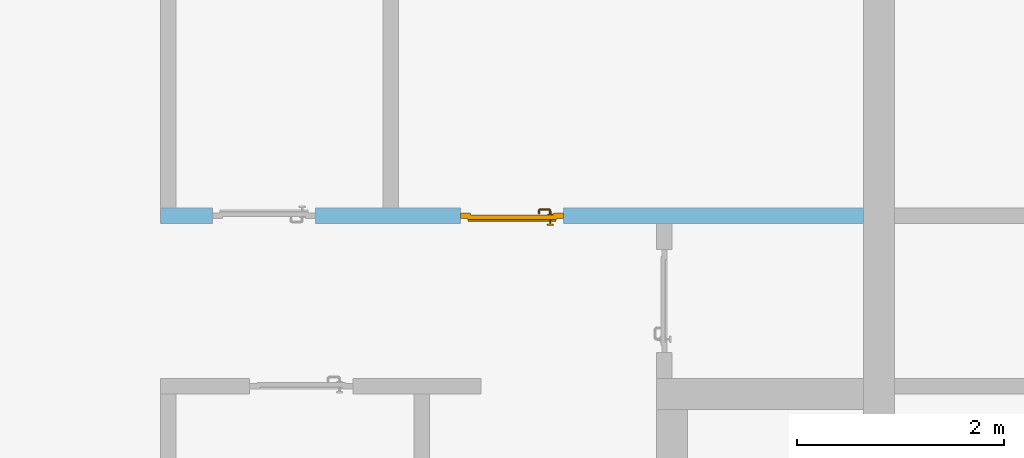
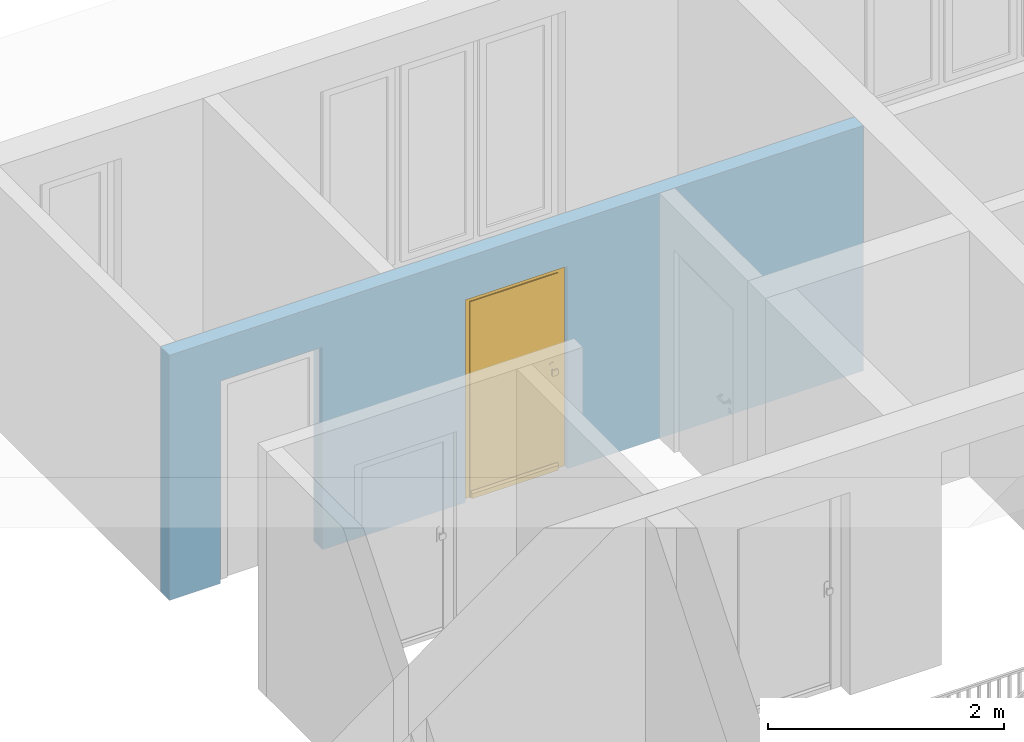
# One storey, part 25 of 54: 1 door, 2 openings, plus 1 element that does not belong to this part.
"""IFC4 building model written with IfcOpenShell, lengths in metres."""

from ifc_helpers import new_model, entity, si_unit, converted_unit, derived_unit, direction, frame, origin_with_axes, place, context, subcontext, project, spatial, polygons, source, transform, mapped, material, type_object, element, fill, save


model = new_model("IFC4")

# Units and contexts
model_context = context("Model", 3, precision=1e-05, world=origin_with_axes(), true_north=direction((0.0, 1.0)))
body_context = subcontext(model_context, "Body", "Model", "MODEL_VIEW")
ifc_project = project(units=[si_unit("LENGTHUNIT", "METRE"), si_unit("AREAUNIT", "SQUARE_METRE"), si_unit("VOLUMEUNIT", "CUBIC_METRE"), converted_unit("PLANEANGLEUNIT", "DEGREE", entity("IfcPlaneAngleMeasure", 0.0174532925199), si_unit("PLANEANGLEUNIT", "RADIAN"), dimensions=[0, 0, 0, 0, 0, 0, 0]), converted_unit("TIMEUNIT", "Year", entity("IfcTimeMeasure", 31556926.0), si_unit("TIMEUNIT", "SECOND"), dimensions=[0, 0, 1, 0, 0, 0, 0]), si_unit("MASSUNIT", "GRAM", prefix="KILO"), si_unit("THERMODYNAMICTEMPERATUREUNIT", "DEGREE_CELSIUS"), si_unit("LUMINOUSINTENSITYUNIT", "LUMEN"), si_unit("ENERGYUNIT", "JOULE", prefix="MEGA"), derived_unit("THERMALCONDUCTANCEUNIT", [(si_unit("POWERUNIT", "WATT"), 1), (si_unit("LENGTHUNIT", "METRE"), -1), (si_unit("THERMODYNAMICTEMPERATUREUNIT", "KELVIN"), -1)]), derived_unit("SPECIFICHEATCAPACITYUNIT", [(si_unit("ENERGYUNIT", "JOULE"), 1), (si_unit("MASSUNIT", "GRAM", prefix="KILO"), -1), (si_unit("THERMODYNAMICTEMPERATUREUNIT", "KELVIN"), -1)]), derived_unit("MASSDENSITYUNIT", [(si_unit("MASSUNIT", "GRAM", prefix="KILO"), 1), (si_unit("VOLUMEUNIT", "CUBIC_METRE"), -1)])], contexts=[model_context])

# Site, building, storey
site_placement = place(None, origin_with_axes())
site = spatial("IfcSite", under=ifc_project, at=site_placement, CompositionType="ELEMENT")
building_placement = place(site_placement, origin_with_axes())
building = spatial("IfcBuilding", under=site, at=building_placement, CompositionType="ELEMENT")
storey_placement = place(building_placement, frame((0.0, 0.0, 6.29), z_axis=(0.0, 0.0, 1.0), x_axis=(1.0, 0.0, 0.0)))
storey = spatial("IfcBuildingStorey", under=building, at=storey_placement, Name="2. Geschoss", CompositionType="ELEMENT", Elevation=6.29)

# Wall, openings, door
ifc_material = material()
wall_type = type_object("IfcWallType", Name="150", PredefinedType="NOTDEFINED")
wall_placement = place(storey_placement, frame((-7.5421993804, 5.47118776896, 0.0), z_axis=(0.0, 0.0, 1.0), x_axis=(1.0, 0.0, 0.0)))
wall = element("IfcWall", 1, at=wall_placement, inside=storey, type_object=wall_type, material=ifc_material, Name="Wand-002", PredefinedType="NOTDEFINED", context=body_context, shape_type="Tessellation", body=[
    polygons([(2.9, 0.15, 2.1), (2.9, 0.15, 0.0), (1.5, 0.15, 0.0), (1.5, 0.15, 2.1), (0.5, 0.15, 2.1), (0.5, 0.15, 0.0), (0.0, 0.15, 0.0), (0.0, 0.15, 2.54), (6.8, 0.15, 2.54), (6.8, 0.15, 0.0), (3.9, 0.15, 0.0), (3.9, 0.15, 2.1), (2.9, 0.05, 2.1), (2.9, 0.05, 0.0), (2.9, 0.0, 0.0), (1.5, 0.0, 0.0), (1.5, 0.1, 0.0), (1.5, 0.1, 2.1), (0.5, 0.1, 2.1), (0.5, 0.1, 0.0), (0.5, 0.0, 0.0), (0.0, 0.0, 0.0), (0.0, 0.0, 2.54), (6.8, 0.0, 2.54), (6.8, 0.0, 0.0), (3.9, 0.05, 0.0), (3.9, 0.0, 0.0), (3.9, 0.05, 2.1), (2.9, 0.0, 2.1), (3.9, 0.0, 2.1), (0.5, 0.0, 2.1), (1.5, 0.0, 2.1)], [[[1, 2, 3, 4, 5, 6, 7, 8, 9, 10, 11, 12]], [[2, 1, 13, 14]], [[2, 14, 15, 16, 17, 3]], [[4, 3, 17, 18]], [[5, 4, 18, 19]], [[6, 5, 19, 20]], [[6, 20, 21, 22, 7]], [[22, 23, 8, 7]], [[23, 24, 9, 8]], [[10, 9, 24, 25]], [[26, 11, 10, 25, 27]], [[12, 11, 26, 28]], [[1, 12, 28, 13]], [[14, 13, 29, 15]], [[16, 15, 29, 30, 27, 25, 24, 23, 22, 21, 31, 32]], [[16, 32, 18, 17]], [[32, 31, 19, 18]], [[31, 21, 20, 19]], [[28, 26, 27, 30]], [[13, 28, 30, 29]]], closed=True),
])
opening_1_placement = place(wall_placement, frame((1.0, 0.0, 0.0), z_axis=(0.0, 0.0, 1.0), x_axis=(1.0, 0.0, 0.0)))
element("IfcOpeningElement", 2, at=opening_1_placement, cuts=wall, context=body_context, identifier="Reference", shape_type="Tessellation", body=[
    polygons([(-0.5, 0.1, 0.0), (-0.5, 0.1, 2.1), (-0.5, 0.151, 2.1), (-0.5, 0.151, 0.0), (-0.5, -0.001, 0.0), (-0.5, -0.001, 2.1), (0.5, 0.1, 2.1), (0.5, 0.151, 2.1), (0.5, -0.001, 2.1), (0.5, 0.151, 0.0), (0.5, 0.1, 0.0), (0.5, -0.001, 0.0)], [[[1, 2, 3, 4]], [[2, 1, 5, 6]], [[7, 8, 3, 2, 6, 9]], [[8, 10, 4, 3]], [[1, 4, 10, 11, 12, 5]], [[6, 5, 12, 9]], [[7, 11, 10, 8]], [[11, 7, 9, 12]]], closed=True),
])
opening_2_placement = place(wall_placement, frame((3.4, 0.0, 0.0), z_axis=(0.0, 0.0, 1.0), x_axis=(1.0, 0.0, 0.0)))
opening_2 = element("IfcOpeningElement", 3, at=opening_2_placement, cuts=wall, context=body_context, identifier="Reference", shape_type="Tessellation", body=[
    polygons([(0.5, 0.05, 0.0), (0.5, 0.05, 2.1), (0.5, -0.001, 2.1), (0.5, -0.001, 0.0), (0.5, 0.151, 0.0), (0.5, 0.151, 2.1), (-0.5, 0.05, 2.1), (-0.5, -0.001, 2.1), (-0.5, 0.151, 2.1), (-0.5, -0.001, 0.0), (-0.5, 0.05, 0.0), (-0.5, 0.151, 0.0)], [[[1, 2, 3, 4]], [[2, 1, 5, 6]], [[7, 8, 3, 2, 6, 9]], [[8, 10, 4, 3]], [[1, 4, 10, 11, 12, 5]], [[6, 5, 12, 9]], [[7, 11, 10, 8]], [[11, 7, 9, 12]]], closed=True),
])
door_type = type_object("IfcDoorType", Name="Eingang 01 1-Fl 26", OperationType="SINGLE_SWING_RIGHT", PredefinedType="DOOR")
shared_shape = source(origin_with_axes(), body_context, "Body", "Tessellation", [
    polygons([(0.5, -0.05, 0.0), (0.5, -0.03, 0.0), (0.5, -0.03, 2.1), (0.5, -0.05, 2.1), (0.4, -0.05, 0.0), (0.4, -0.03, 0.0), (0.4, -0.03, 2.0), (0.1301, -0.03, 2.0), (0.0001, -0.03, 2.0), (-0.4, -0.03, 2.0), (-0.4, -0.03, 0.0), (-0.5, -0.03, 0.0), (-0.5, -0.03, 2.1), (-0.5, -0.05, 2.1), (-0.5, -0.05, 0.0), (-0.4, -0.05, 0.0), (-0.4, -0.05, 2.0), (0.0001, -0.05, 2.0), (0.1301, -0.05, 2.0), (0.4, -0.05, 2.0)], [[[1, 2, 3, 4]], [[5, 6, 2, 1]], [[2, 6, 7, 8, 9, 10, 11, 12, 13, 3]], [[4, 3, 13, 14]], [[1, 4, 14, 15, 16, 17, 18, 19, 20, 5]], [[20, 7, 6, 5]], [[19, 8, 7, 20]], [[18, 9, 8, 19]], [[17, 10, 9, 18]], [[16, 11, 10, 17]], [[15, 12, 11, 16]], [[14, 13, 12, 15]]], closed=True),
    polygons([(0.5, -0.03, 0.0), (0.5, 0.0, 0.0), (0.5, 0.0, 2.1), (0.5, -0.03, 2.1), (0.43, -0.03, 0.0), (0.43, 0.0, 0.0), (0.43, 0.0, 2.03), (0.1001, 0.0, 2.03), (0.0301, 0.0, 2.03), (-0.43, 0.0, 2.03), (-0.43, 0.0, 0.0), (-0.5, 0.0, 0.0), (-0.5, 0.0, 2.1), (-0.5, -0.03, 2.1), (-0.5, -0.03, 0.0), (-0.43, -0.03, 0.0), (-0.43, -0.03, 2.03), (0.0301, -0.03, 2.03), (0.1001, -0.03, 2.03), (0.43, -0.03, 2.03)], [[[1, 2, 3, 4]], [[5, 6, 2, 1]], [[2, 6, 7, 8, 9, 10, 11, 12, 13, 3]], [[4, 3, 13, 14]], [[1, 4, 14, 15, 16, 17, 18, 19, 20, 5]], [[20, 7, 6, 5]], [[19, 8, 7, 20]], [[18, 9, 8, 19]], [[17, 10, 9, 18]], [[16, 11, 10, 17]], [[15, 12, 11, 16]], [[14, 13, 12, 15]]], closed=True),
    polygons([(0.43, 0.01, 0.0), (-0.43, 0.01, 0.0), (-0.43, 0.01, 2.03), (0.43, 0.01, 2.03), (0.43, -0.03, 0.0), (-0.43, -0.03, 0.0), (-0.43, -0.03, 2.03), (0.43, -0.03, 2.03)], [[[1, 2, 3, 4]], [[2, 1, 5, 6]], [[3, 2, 6, 7]], [[4, 3, 7, 8]], [[1, 4, 8, 5]], [[6, 5, 8, 7]]], closed=True),
    polygons([(0.425, 0.03, 0.0), (-0.425, 0.03, 0.0), (-0.425, 0.03, 0.05), (0.425, 0.03, 0.05), (0.425, 0.01, 0.0), (-0.425, 0.01, 0.0), (-0.425, 0.01, 0.07), (-0.425, 0.015, 0.07), (0.425, 0.015, 0.07), (0.425, 0.01, 0.07)], [[[1, 2, 3, 4]], [[5, 6, 2, 1]], [[2, 6, 7, 8, 3]], [[4, 3, 8, 9]], [[1, 4, 9, 10, 5]], [[10, 7, 6, 5]], [[9, 8, 7, 10]]], closed=True),
    polygons([(-0.3835, -0.04, 1.0733826859), (-0.37, -0.04, 1.077), (-0.37, -0.0399, 1.077), (-0.3835, -0.0399, 1.0733826859), (-0.393382685902, -0.04, 1.0635), (-0.397, -0.04, 1.05), (-0.393382685902, -0.04, 1.0365), (-0.3835, -0.04, 1.0266173141), (-0.37, -0.04, 1.023), (-0.3565, -0.04, 1.0266173141), (-0.346617314098, -0.04, 1.0365), (-0.343, -0.04, 1.05), (-0.346617314098, -0.04, 1.0635), (-0.3565, -0.04, 1.0733826859), (-0.3565, -0.0399, 1.0733826859), (-0.37, -0.0301, 1.077), (-0.3835, -0.0301, 1.0733826859), (-0.393382685902, -0.0399, 1.0635), (-0.397, -0.0399, 1.05), (-0.393382685902, -0.0399, 1.0365), (-0.3835, -0.0399, 1.0266173141), (-0.37, -0.0399, 1.023), (-0.3565, -0.0399, 1.0266173141), (-0.346617314098, -0.0399, 1.0365), (-0.343, -0.0399, 1.05), (-0.346617314098, -0.0399, 1.0635), (-0.3565, -0.0301, 1.0733826859), (-0.37, -0.03, 1.077), (-0.3835, -0.03, 1.0733826859), (-0.393382685902, -0.0301, 1.0635), (-0.397, -0.0301, 1.05), (-0.393382685902, -0.0301, 1.0365), (-0.3835, -0.0301, 1.0266173141), (-0.37, -0.0301, 1.023), (-0.3565, -0.0301, 1.0266173141), (-0.346617314098, -0.0301, 1.0365), (-0.343, -0.0301, 1.05), (-0.346617314098, -0.0301, 1.0635), (-0.3565, -0.03, 1.0733826859), (-0.346617314098, -0.03, 1.0635), (-0.343, -0.03, 1.05), (-0.346617314098, -0.03, 1.0365), (-0.3565, -0.03, 1.0266173141), (-0.37, -0.03, 1.023), (-0.3835, -0.03, 1.0266173141), (-0.393382685902, -0.03, 1.0365), (-0.397, -0.03, 1.05), (-0.393382685902, -0.03, 1.0635)], [[[1, 2, 3, 4]], [[2, 1, 5, 6, 7, 8, 9, 10, 11, 12, 13, 14]], [[2, 14, 15, 3]], [[4, 3, 16, 17]], [[5, 1, 4, 18]], [[6, 5, 18, 19]], [[7, 6, 19, 20]], [[8, 7, 20, 21]], [[9, 8, 21, 22]], [[10, 9, 22, 23]], [[11, 10, 23, 24]], [[12, 11, 24, 25]], [[13, 12, 25, 26]], [[14, 13, 26, 15]], [[3, 15, 27, 16]], [[17, 16, 28, 29]], [[18, 4, 17, 30]], [[19, 18, 30, 31]], [[20, 19, 31, 32]], [[21, 20, 32, 33]], [[22, 21, 33, 34]], [[23, 22, 34, 35]], [[24, 23, 35, 36]], [[25, 24, 36, 37]], [[26, 25, 37, 38]], [[15, 26, 38, 27]], [[16, 27, 39, 28]], [[28, 39, 40, 41, 42, 43, 44, 45, 46, 47, 48, 29]], [[30, 17, 29, 48]], [[31, 30, 48, 47]], [[32, 31, 47, 46]], [[33, 32, 46, 45]], [[34, 33, 45, 44]], [[35, 34, 44, 43]], [[36, 35, 43, 42]], [[37, 36, 42, 41]], [[38, 37, 41, 40]], [[27, 38, 40, 39]]], closed=True),
    polygons([(-0.362532169224, -0.04, 0.959692280177), (-0.365, -0.04, 0.9544), (-0.365, -0.04, 0.952886751346), (-0.346703916638, -0.04, 0.96345), (-0.35655, -0.04, 0.973296083362), (-0.363279754556, -0.04, 0.961639806549), (-0.362532169224, -0.039, 0.959692280177), (-0.365, -0.039, 0.9544), (-0.365, -0.039, 0.952886751346), (-0.365, -0.039, 0.95), (-0.365, -0.039, 0.947113248654), (-0.365, -0.039, 0.941339745962), (-0.365, -0.039, 0.9375), (-0.365, -0.04, 0.9375), (-0.365, -0.04, 0.941339745962), (-0.365, -0.04, 0.947113248654), (-0.365, -0.04, 0.95), (-0.3431, -0.04, 0.95), (-0.346617314098, -0.04, 0.9635), (-0.3565, -0.04, 0.973382685902), (-0.364624817685, -0.04, 0.965143815798), (-0.37, -0.04, 0.9769), (-0.37, -0.04, 0.967425445323), (-0.364624817685, -0.039, 0.965143815798), (-0.363279754556, -0.039, 0.961639806549), (-0.35705, -0.039, 0.972430057958), (-0.347569942042, -0.039, 0.96295), (-0.3441, -0.039, 0.95), (-0.347569942042, -0.039, 0.93705), (-0.35705, -0.039, 0.927569942042), (-0.37, -0.039, 0.9241), (-0.37, -0.039, 0.9325), (-0.366464466094, -0.039, 0.933964466094), (-0.366464466094, -0.04, 0.933964466094), (-0.35655, -0.04, 0.926703916638), (-0.37, -0.04, 0.9325), (-0.37, -0.04, 0.9231), (-0.346703916638, -0.04, 0.93655), (-0.343, -0.04, 0.95), (-0.346617314098, -0.0399, 0.9635), (-0.3565, -0.0399, 0.973382685902), (-0.37, -0.04, 0.977), (-0.375375182315, -0.04, 0.965143815798), (-0.38345, -0.04, 0.973296083362), (-0.376720245444, -0.04, 0.961639806549), (-0.37, -0.039, 0.967425445323), (-0.37, -0.039, 0.9759), (-0.357, -0.039, 0.972516660498), (-0.347483339502, -0.039, 0.963), (-0.344, -0.039, 0.95), (-0.347483339502, -0.039, 0.937), (-0.357, -0.039, 0.927483339502), (-0.38295, -0.039, 0.927569942042), (-0.375, -0.039, 0.941339745962), (-0.375, -0.039, 0.9375), (-0.373535533906, -0.039, 0.933964466094), (-0.37, -0.039, 0.924), (-0.373535533906, -0.04, 0.933964466094), (-0.375, -0.04, 0.9375), (-0.375, -0.04, 0.941339745962), (-0.38345, -0.04, 0.926703916638), (-0.37, -0.04, 0.923), (-0.3565, -0.04, 0.926617314098), (-0.346617314098, -0.04, 0.9365), (-0.343, -0.0399, 0.95), (-0.346617314098, -0.0301, 0.9635), (-0.3565, -0.0301, 0.973382685902), (-0.37, -0.0399, 0.977), (-0.3835, -0.04, 0.973382685902), (-0.375375182315, -0.039, 0.965143815798), (-0.377467830776, -0.04, 0.959692280177), (-0.393296083362, -0.04, 0.96345), (-0.375, -0.04, 0.952886751346), (-0.375, -0.04, 0.9544), (-0.377467830776, -0.039, 0.959692280177), (-0.376720245444, -0.039, 0.961639806549), (-0.38295, -0.039, 0.972430057958), (-0.37, -0.039, 0.976), (-0.357, -0.0389, 0.972516660498), (-0.347483339502, -0.0389, 0.963), (-0.344, -0.0389, 0.95), (-0.347483339502, -0.0389, 0.937), (-0.357, -0.0389, 0.927483339502), (-0.392430057958, -0.039, 0.93705), (-0.375, -0.039, 0.947113248654), (-0.375, -0.039, 0.9544), (-0.375, -0.04, 0.95), (-0.375, -0.04, 0.947113248654), (-0.375, -0.039, 0.95), (-0.375, -0.039, 0.952886751346), (-0.383, -0.039, 0.927483339502), (-0.37, -0.0389, 0.924), (-0.393296083362, -0.04, 0.93655), (-0.3835, -0.04, 0.926617314098), (-0.37, -0.0399, 0.923), (-0.3565, -0.0399, 0.926617314098), (-0.346617314098, -0.0399, 0.9365), (-0.343, -0.0301, 0.95), (-0.346617314098, -0.03, 0.9635), (-0.3565, -0.03, 0.973382685902), (-0.37, -0.0301, 0.977), (-0.3835, -0.0399, 0.973382685902), (-0.393382685902, -0.04, 0.9635), (-0.3969, -0.04, 0.95), (-0.392430057958, -0.039, 0.96295), (-0.383, -0.039, 0.972516660498), (-0.37, -0.0389, 0.976), (-0.357, -0.0301, 0.972516660498), (-0.347483339502, -0.0301, 0.963), (-0.344, -0.0301, 0.95), (-0.347483339502, -0.0301, 0.937), (-0.357, -0.0301, 0.927483339502), (-0.392516660498, -0.039, 0.937), (-0.3959, -0.039, 0.95), (-0.383, -0.0389, 0.927483339502), (-0.37, -0.0301, 0.924), (-0.393382685902, -0.04, 0.9365), (-0.3835, -0.0399, 0.926617314098), (-0.37, -0.0301, 0.923), (-0.3565, -0.0301, 0.926617314098), (-0.346617314098, -0.0301, 0.9365), (-0.343, -0.03, 0.95), (-0.346703916638, -0.03, 0.96345), (-0.35655, -0.03, 0.973296083362), (-0.37, -0.03, 0.977), (-0.3835, -0.0301, 0.973382685902), (-0.393382685902, -0.0399, 0.9635), (-0.397, -0.04, 0.95), (-0.392516660498, -0.039, 0.963), (-0.383, -0.0389, 0.972516660498), (-0.37, -0.0301, 0.976), (-0.357, -0.03, 0.972516660498), (-0.347483339502, -0.03, 0.963), (-0.344, -0.03, 0.95), (-0.347483339502, -0.03, 0.937), (-0.357, -0.03, 0.927483339502), (-0.392516660498, -0.0389, 0.937), (-0.396, -0.039, 0.95), (-0.383, -0.0301, 0.927483339502), (-0.37, -0.03, 0.924), (-0.393382685902, -0.0399, 0.9365), (-0.3835, -0.0301, 0.926617314098), (-0.37, -0.03, 0.923), (-0.3565, -0.03, 0.926617314098), (-0.346617314098, -0.03, 0.9365), (-0.3431, -0.03, 0.95), (-0.347396736961, -0.03, 0.96305), (-0.35695, -0.03, 0.972603263039), (-0.37, -0.03, 0.9769), (-0.3835, -0.03, 0.973382685902), (-0.393382685902, -0.0301, 0.9635), (-0.397, -0.0399, 0.95), (-0.392516660498, -0.0389, 0.963), (-0.383, -0.0301, 0.972516660498), (-0.37, -0.03, 0.976), (-0.3439, -0.03, 0.95), (-0.347396736961, -0.03, 0.93695), (-0.35695, -0.03, 0.927396736961), (-0.392516660498, -0.0301, 0.937), (-0.396, -0.0389, 0.95), (-0.383, -0.03, 0.927483339502), (-0.37, -0.03, 0.9239), (-0.393382685902, -0.0301, 0.9365), (-0.3835, -0.03, 0.926617314098), (-0.37, -0.03, 0.9231), (-0.35655, -0.03, 0.926703916638), (-0.346703916638, -0.03, 0.93655), (-0.37, -0.03, 0.9761), (-0.38345, -0.03, 0.973296083362), (-0.393382685902, -0.03, 0.9635), (-0.397, -0.0301, 0.95), (-0.392516660498, -0.0301, 0.963), (-0.383, -0.03, 0.972516660498), (-0.392516660498, -0.03, 0.937), (-0.396, -0.0301, 0.95), (-0.38305, -0.03, 0.927396736961), (-0.393382685902, -0.03, 0.9365), (-0.38345, -0.03, 0.926703916638), (-0.38305, -0.03, 0.972603263039), (-0.393296083362, -0.03, 0.96345), (-0.397, -0.03, 0.95), (-0.392516660498, -0.03, 0.963), (-0.392603263039, -0.03, 0.93695), (-0.396, -0.03, 0.95), (-0.393296083362, -0.03, 0.93655), (-0.392603263039, -0.03, 0.96305), (-0.3969, -0.03, 0.95), (-0.3961, -0.03, 0.95)], [[[1, 2, 3, 4, 5, 6]], [[2, 1, 7, 8]], [[2, 8, 9, 10, 11, 12, 13, 14, 15, 16, 17, 3]], [[17, 18, 4, 3]], [[19, 20, 5, 4]], [[21, 6, 5, 22, 23]], [[1, 6, 21, 24, 25, 7]], [[7, 25, 26, 27, 9, 8]], [[9, 27, 28, 10]], [[10, 28, 29, 11]], [[11, 29, 30, 12]], [[31, 32, 33, 13, 12, 30]], [[14, 13, 33, 34]], [[35, 15, 14, 34, 36, 37]], [[15, 35, 38, 16]], [[16, 38, 18, 17]], [[39, 19, 4, 18]], [[40, 41, 20, 19]], [[20, 42, 22, 5]], [[43, 23, 22, 44, 45]], [[21, 23, 46, 24]], [[24, 46, 47, 26, 25]], [[27, 26, 48, 49]], [[28, 27, 49, 50]], [[29, 28, 50, 51]], [[30, 29, 51, 52]], [[53, 54, 55, 56, 32, 31]], [[34, 33, 32, 36]], [[31, 30, 52, 57]], [[37, 36, 58, 59, 60, 61]], [[62, 63, 35, 37]], [[63, 64, 38, 35]], [[64, 39, 18, 38]], [[65, 40, 19, 39]], [[66, 67, 41, 40]], [[41, 68, 42, 20]], [[42, 69, 44, 22]], [[23, 43, 70, 46]], [[71, 45, 44, 72, 73, 74]], [[43, 45, 71, 75, 76, 70]], [[70, 76, 77, 47, 46]], [[26, 47, 78, 48]], [[49, 48, 79, 80]], [[50, 49, 80, 81]], [[51, 50, 81, 82]], [[52, 51, 82, 83]], [[54, 53, 84, 85]], [[86, 74, 73, 87, 88, 60, 59, 55, 54, 85, 89, 90]], [[58, 56, 55, 59]], [[36, 32, 56, 58]], [[53, 31, 57, 91]], [[57, 52, 83, 92]], [[88, 93, 61, 60]], [[94, 62, 37, 61]], [[95, 96, 63, 62]], [[96, 97, 64, 63]], [[97, 65, 39, 64]], [[98, 66, 40, 65]], [[99, 100, 67, 66]], [[67, 101, 68, 41]], [[68, 102, 69, 42]], [[69, 103, 72, 44]], [[73, 72, 104, 87]], [[71, 74, 86, 75]], [[75, 86, 90, 105, 77, 76]], [[47, 77, 106, 78]], [[48, 78, 107, 79]], [[80, 79, 108, 109]], [[81, 80, 109, 110]], [[82, 81, 110, 111]], [[83, 82, 111, 112]], [[84, 53, 91, 113]], [[85, 84, 114, 89]], [[87, 104, 93, 88]], [[89, 114, 105, 90]], [[91, 57, 92, 115]], [[92, 83, 112, 116]], [[117, 94, 61, 93]], [[118, 95, 62, 94]], [[119, 120, 96, 95]], [[120, 121, 97, 96]], [[121, 98, 65, 97]], [[122, 99, 66, 98]], [[123, 124, 100, 99]], [[100, 125, 101, 67]], [[101, 126, 102, 68]], [[102, 127, 103, 69]], [[103, 128, 104, 72]], [[77, 105, 129, 106]], [[78, 106, 130, 107]], [[79, 107, 131, 108]], [[109, 108, 132, 133]], [[110, 109, 133, 134]], [[111, 110, 134, 135]], [[112, 111, 135, 136]], [[113, 91, 115, 137]], [[114, 84, 113, 138]], [[128, 117, 93, 104]], [[105, 114, 138, 129]], [[115, 92, 116, 139]], [[116, 112, 136, 140]], [[141, 118, 94, 117]], [[142, 119, 95, 118]], [[143, 144, 120, 119]], [[144, 145, 121, 120]], [[145, 122, 98, 121]], [[146, 123, 99, 122]], [[147, 148, 124, 123]], [[124, 149, 125, 100]], [[125, 150, 126, 101]], [[126, 151, 127, 102]], [[127, 152, 128, 103]], [[106, 129, 153, 130]], [[107, 130, 154, 131]], [[108, 131, 155, 132]], [[133, 132, 148, 147]], [[134, 133, 147, 156]], [[135, 134, 156, 157]], [[136, 135, 157, 158]], [[137, 115, 139, 159]], [[138, 113, 137, 160]], [[152, 141, 117, 128]], [[129, 138, 160, 153]], [[139, 116, 140, 161]], [[140, 136, 158, 162]], [[163, 142, 118, 141]], [[164, 143, 119, 142]], [[165, 166, 144, 143]], [[166, 167, 145, 144]], [[167, 146, 122, 145]], [[156, 147, 123, 146]], [[148, 168, 149, 124]], [[149, 169, 150, 125]], [[150, 170, 151, 126]], [[151, 171, 152, 127]], [[130, 153, 172, 154]], [[131, 154, 173, 155]], [[132, 155, 168, 148]], [[157, 156, 146, 167]], [[158, 157, 167, 166]], [[159, 139, 161, 174]], [[160, 137, 159, 175]], [[171, 163, 141, 152]], [[153, 160, 175, 172]], [[161, 140, 162, 176]], [[162, 158, 166, 165]], [[177, 164, 142, 163]], [[178, 165, 143, 164]], [[168, 179, 169, 149]], [[169, 180, 170, 150]], [[170, 181, 171, 151]], [[154, 172, 182, 173]], [[155, 173, 179, 168]], [[174, 161, 176, 183]], [[175, 159, 174, 184]], [[181, 177, 163, 171]], [[172, 175, 184, 182]], [[176, 162, 165, 178]], [[185, 178, 164, 177]], [[179, 186, 180, 169]], [[180, 187, 181, 170]], [[173, 182, 186, 179]], [[183, 176, 178, 185]], [[184, 174, 183, 188]], [[187, 185, 177, 181]], [[182, 184, 188, 186]], [[186, 188, 187, 180]], [[188, 183, 185, 187]]], closed=True),
    polygons([(-0.38, -0.04, 1.05), (-0.377071067812, -0.04, 1.04292893219), (-0.377071067812, -0.070696439392, 1.04292893219), (-0.38, -0.0709849140336, 1.05), (-0.37, -0.04, 1.04), (-0.37, -0.07, 1.04), (-0.375518993221, -0.0784992452783, 1.04292893219), (-0.378277987014, -0.0796420579258, 1.05), (-0.377071067812, -0.04, 1.05707106781), (-0.377071067812, -0.070696439392, 1.05707106781), (-0.362928932188, -0.04, 1.04292893219), (-0.362928932188, -0.069303560608, 1.04292893219), (-0.368858192988, -0.0757402514855, 1.04), (-0.370704557509, -0.0857045575088, 1.04292893219), (-0.372816199938, -0.0878161999379, 1.05), (-0.375518993221, -0.0784992452783, 1.05707106781), (-0.37, -0.04, 1.06), (-0.37, -0.07, 1.06), (-0.36, -0.04, 1.05), (-0.36, -0.0690150859664, 1.05), (-0.362197392755, -0.0729812576926, 1.04292893219), (-0.365606601718, -0.0806066017178, 1.04), (-0.363499245278, -0.0905189932208, 1.04292893219), (-0.364642057926, -0.0932779870137, 1.05), (-0.370704557509, -0.0857045575088, 1.05707106781), (-0.368858192988, -0.0757402514855, 1.06), (-0.362928932188, -0.04, 1.05707106781), (-0.362928932188, -0.069303560608, 1.05707106781), (-0.359438398962, -0.0718384450452, 1.05), (-0.360508645927, -0.0755086459268, 1.04292893219), (-0.360740251485, -0.0838581929877, 1.04), (-0.355696439392, -0.0920710678119, 1.04292893219), (-0.355984914034, -0.095, 1.05), (-0.363499245278, -0.0905189932208, 1.05707106781), (-0.365606601718, -0.0806066017178, 1.06), (-0.362197392755, -0.0729812576926, 1.05707106781), (-0.358397003498, -0.0733970034977, 1.05), (-0.357981257693, -0.0771973927545, 1.04292893219), (-0.355, -0.085, 1.04), (-0.274303560608, -0.0920710678119, 1.04292893219), (-0.274015085966, -0.095, 1.05), (-0.355696439392, -0.0920710678119, 1.05707106781), (-0.360740251485, -0.0838581929877, 1.06), (-0.360508645927, -0.0755086459268, 1.05707106781), (-0.356838445045, -0.0744383989617, 1.05), (-0.354303560608, -0.0779289321881, 1.04292893219), (-0.275, -0.085, 1.04), (-0.266500754722, -0.0905189932208, 1.04292893219), (-0.265357942074, -0.0932779870137, 1.05), (-0.274303560608, -0.0920710678119, 1.05707106781), (-0.355, -0.085, 1.06), (-0.357981257693, -0.0771973927545, 1.05707106781), (-0.354015085966, -0.075, 1.05), (-0.275696439392, -0.0779289321881, 1.04292893219), (-0.269259748515, -0.0838581929877, 1.04), (-0.259295442491, -0.0857045575088, 1.04292893219), (-0.257183800062, -0.0878161999379, 1.05), (-0.266500754722, -0.0905189932208, 1.05707106781), (-0.275, -0.085, 1.06), (-0.354303560608, -0.0779289321881, 1.05707106781), (-0.275984914034, -0.075, 1.05), (-0.272018742307, -0.0771973927545, 1.04292893219), (-0.264393398282, -0.0806066017178, 1.04), (-0.254481006779, -0.0784992452783, 1.04292893219), (-0.251722012986, -0.0796420579258, 1.05), (-0.259295442491, -0.0857045575088, 1.05707106781), (-0.269259748515, -0.0838581929877, 1.06), (-0.275696439392, -0.0779289321881, 1.05707106781), (-0.273161554955, -0.0744383989617, 1.05), (-0.269491354073, -0.0755086459268, 1.04292893219), (-0.261141807012, -0.0757402514855, 1.04), (-0.252928932188, -0.070696439392, 1.04292893219), (-0.25, -0.0709849140336, 1.05), (-0.254481006779, -0.0784992452783, 1.05707106781), (-0.264393398282, -0.0806066017178, 1.06), (-0.272018742307, -0.0771973927545, 1.05707106781), (-0.271602996502, -0.0733970034977, 1.05), (-0.267802607245, -0.0729812576926, 1.04292893219), (-0.26, -0.07, 1.04), (-0.252928932188, -0.04, 1.04292893219), (-0.25, -0.04, 1.05), (-0.252928932188, -0.070696439392, 1.05707106781), (-0.261141807012, -0.0757402514855, 1.06), (-0.269491354073, -0.0755086459268, 1.05707106781), (-0.270561601038, -0.0718384450452, 1.05), (-0.267071067812, -0.069303560608, 1.04292893219), (-0.26, -0.04, 1.04), (-0.267071067812, -0.04, 1.04292893219), (-0.27, -0.04, 1.05), (-0.267071067812, -0.04, 1.05707106781), (-0.26, -0.04, 1.06), (-0.252928932188, -0.04, 1.05707106781), (-0.26, -0.07, 1.06), (-0.267802607245, -0.0729812576926, 1.05707106781), (-0.27, -0.0690150859664, 1.05), (-0.267071067812, -0.069303560608, 1.05707106781)], [[[1, 2, 3, 4]], [[2, 5, 6, 3]], [[4, 3, 7, 8]], [[9, 1, 4, 10]], [[5, 11, 12, 6]], [[3, 6, 13, 7]], [[8, 7, 14, 15]], [[10, 4, 8, 16]], [[17, 9, 10, 18]], [[11, 19, 20, 12]], [[6, 12, 21, 13]], [[7, 13, 22, 14]], [[15, 14, 23, 24]], [[16, 8, 15, 25]], [[18, 10, 16, 26]], [[27, 17, 18, 28]], [[19, 27, 28, 20]], [[12, 20, 29, 21]], [[13, 21, 30, 22]], [[14, 22, 31, 23]], [[24, 23, 32, 33]], [[25, 15, 24, 34]], [[26, 16, 25, 35]], [[28, 18, 26, 36]], [[20, 28, 36, 29]], [[21, 29, 37, 30]], [[22, 30, 38, 31]], [[23, 31, 39, 32]], [[33, 32, 40, 41]], [[34, 24, 33, 42]], [[35, 25, 34, 43]], [[36, 26, 35, 44]], [[29, 36, 44, 37]], [[30, 37, 45, 38]], [[31, 38, 46, 39]], [[32, 39, 47, 40]], [[41, 40, 48, 49]], [[42, 33, 41, 50]], [[43, 34, 42, 51]], [[44, 35, 43, 52]], [[37, 44, 52, 45]], [[38, 45, 53, 46]], [[39, 46, 54, 47]], [[40, 47, 55, 48]], [[49, 48, 56, 57]], [[50, 41, 49, 58]], [[51, 42, 50, 59]], [[52, 43, 51, 60]], [[45, 52, 60, 53]], [[46, 53, 61, 54]], [[47, 54, 62, 55]], [[48, 55, 63, 56]], [[57, 56, 64, 65]], [[58, 49, 57, 66]], [[59, 50, 58, 67]], [[60, 51, 59, 68]], [[53, 60, 68, 61]], [[54, 61, 69, 62]], [[55, 62, 70, 63]], [[56, 63, 71, 64]], [[65, 64, 72, 73]], [[66, 57, 65, 74]], [[67, 58, 66, 75]], [[68, 59, 67, 76]], [[61, 68, 76, 69]], [[62, 69, 77, 70]], [[63, 70, 78, 71]], [[64, 71, 79, 72]], [[73, 72, 80, 81]], [[74, 65, 73, 82]], [[75, 66, 74, 83]], [[76, 67, 75, 84]], [[69, 76, 84, 77]], [[70, 77, 85, 78]], [[71, 78, 86, 79]], [[72, 79, 87, 80]], [[81, 80, 87, 88, 89, 90, 91, 92]], [[82, 73, 81, 92]], [[83, 74, 82, 93]], [[84, 75, 83, 94]], [[77, 84, 94, 85]], [[78, 85, 95, 86]], [[79, 86, 88, 87]], [[86, 95, 89, 88]], [[95, 96, 90, 89]], [[96, 93, 91, 90]], [[93, 82, 92, 91]], [[94, 83, 93, 96]], [[85, 94, 96, 95]]], closed=False),
    polygons([(-0.364696699141, 0.015, 1.04469669914), (-0.3625, 0.015, 1.05), (-0.364696699141, 0.015, 1.05530330086), (-0.37, 0.015, 1.0575), (-0.375303300859, 0.015, 1.05530330086), (-0.3775, 0.015, 1.05), (-0.375303300859, 0.015, 1.04469669914), (-0.37, 0.015, 1.0425), (-0.364696699141, 0.055, 1.04469669914), (-0.3625, 0.055, 1.05), (-0.364696699141, 0.055, 1.05530330086), (-0.37, 0.055, 1.0575), (-0.375303300859, 0.055, 1.05530330086), (-0.3775, 0.055, 1.05), (-0.375303300859, 0.055, 1.04469669914), (-0.37, 0.055, 1.0425)], [[[1, 2, 3, 4, 5, 6, 7, 8]], [[1, 9, 10, 2]], [[2, 10, 11, 3]], [[3, 11, 12, 4]], [[4, 12, 13, 5]], [[5, 13, 14, 6]], [[6, 14, 15, 7]], [[7, 15, 16, 8]], [[8, 16, 9, 1]], [[9, 16, 15, 14, 13, 12, 11, 10]]], closed=True),
    polygons([(-0.395, 0.01, 0.975), (-0.395, 0.015, 0.975), (-0.393096988313, 0.015, 0.965432914191), (-0.393096988313, 0.01, 0.965432914191), (-0.395, 0.01, 1.1), (-0.395, 0.015, 1.1), (-0.393096988313, 0.015, 1.10956708581), (-0.38767766953, 0.015, 1.11767766953), (-0.379567085809, 0.015, 1.12309698831), (-0.37, 0.015, 1.125), (-0.360432914191, 0.015, 1.12309698831), (-0.35232233047, 0.015, 1.11767766953), (-0.346903011687, 0.015, 1.10956708581), (-0.345, 0.015, 1.1), (-0.345, 0.015, 0.975), (-0.346903011687, 0.015, 0.965432914191), (-0.35232233047, 0.015, 0.95732233047), (-0.360432914191, 0.015, 0.951903011687), (-0.37, 0.015, 0.95), (-0.379567085809, 0.015, 0.951903011687), (-0.38767766953, 0.015, 0.95732233047), (-0.38767766953, 0.01, 0.95732233047), (-0.379567085809, 0.01, 0.951903011687), (-0.37, 0.01, 0.95), (-0.360432914191, 0.01, 0.951903011687), (-0.35232233047, 0.01, 0.95732233047), (-0.346903011687, 0.01, 0.965432914191), (-0.345, 0.01, 0.975), (-0.345, 0.01, 1.1), (-0.346903011687, 0.01, 1.10956708581), (-0.35232233047, 0.01, 1.11767766953), (-0.360432914191, 0.01, 1.12309698831), (-0.37, 0.01, 1.125), (-0.379567085809, 0.01, 1.12309698831), (-0.38767766953, 0.01, 1.11767766953), (-0.393096988313, 0.01, 1.10956708581)], [[[1, 2, 3, 4]], [[5, 6, 2, 1]], [[2, 6, 7, 8, 9, 10, 11, 12, 13, 14, 15, 16, 17, 18, 19, 20, 21, 3]], [[4, 3, 21, 22]], [[1, 4, 22, 23, 24, 25, 26, 27, 28, 29, 30, 31, 32, 33, 34, 35, 36, 5]], [[36, 7, 6, 5]], [[35, 8, 7, 36]], [[34, 9, 8, 35]], [[33, 10, 9, 34]], [[32, 11, 10, 33]], [[31, 12, 11, 32]], [[30, 13, 12, 31]], [[29, 14, 13, 30]], [[28, 15, 14, 29]], [[27, 16, 15, 28]], [[26, 17, 16, 27]], [[25, 18, 17, 26]], [[24, 19, 18, 25]], [[23, 20, 19, 24]], [[22, 21, 20, 23]]], closed=True),
    polygons([(-0.39, 0.055, 1.08), (-0.39, 0.07, 1.08), (-0.395, 0.07, 1.07866025404), (-0.395, 0.055, 1.07866025404), (-0.35, 0.055, 1.08), (-0.35, 0.07, 1.08), (-0.345, 0.07, 1.07866025404), (-0.341339745962, 0.07, 1.075), (-0.34, 0.07, 1.07), (-0.34, 0.07, 1.03), (-0.341339745962, 0.07, 1.025), (-0.345, 0.07, 1.02133974596), (-0.35, 0.07, 1.02), (-0.39, 0.07, 1.02), (-0.395, 0.07, 1.02133974596), (-0.398660254038, 0.07, 1.025), (-0.4, 0.07, 1.03), (-0.4, 0.07, 1.07), (-0.398660254038, 0.07, 1.075), (-0.398660254038, 0.055, 1.075), (-0.4, 0.055, 1.07), (-0.4, 0.055, 1.03), (-0.398660254038, 0.055, 1.025), (-0.395, 0.055, 1.02133974596), (-0.39, 0.055, 1.02), (-0.35, 0.055, 1.02), (-0.345, 0.055, 1.02133974596), (-0.341339745962, 0.055, 1.025), (-0.34, 0.055, 1.03), (-0.34, 0.055, 1.07), (-0.341339745962, 0.055, 1.075), (-0.345, 0.055, 1.07866025404)], [[[1, 2, 3, 4]], [[5, 6, 2, 1]], [[2, 6, 7, 8, 9, 10, 11, 12, 13, 14, 15, 16, 17, 18, 19, 3]], [[4, 3, 19, 20]], [[1, 4, 20, 21, 22, 23, 24, 25, 26, 27, 28, 29, 30, 31, 32, 5]], [[32, 7, 6, 5]], [[31, 8, 7, 32]], [[30, 9, 8, 31]], [[29, 10, 9, 30]], [[28, 11, 10, 29]], [[27, 12, 11, 28]], [[26, 13, 12, 27]], [[25, 14, 13, 26]], [[24, 15, 14, 25]], [[23, 16, 15, 24]], [[22, 17, 16, 23]], [[21, 18, 17, 22]], [[20, 19, 18, 21]]], closed=True),
])
door_placement = place(opening_2_placement, frame((0.4, 0.0, 0.0), z_axis=(0.0, 0.0, 1.0), x_axis=(-1.0, 0.0, 0.0)))
door = element("IfcDoor", 4, at=door_placement, inside=storey, type_object=door_type, OverallHeight=2.1, OverallWidth=1.0, PredefinedType="DOOR", context=body_context, shape_type="MappedRepresentation", body=[
    mapped(shared_shape, transform((0.4, -0.05, 0.0))),
])
fill(opening_2, door)

save(model, "model.ifc")
